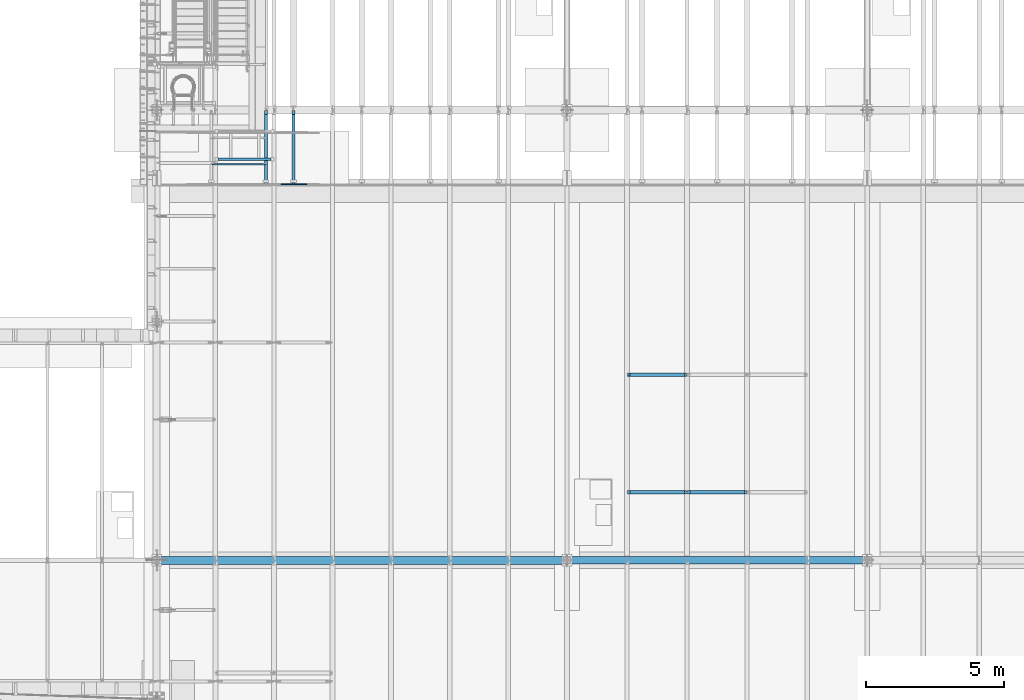
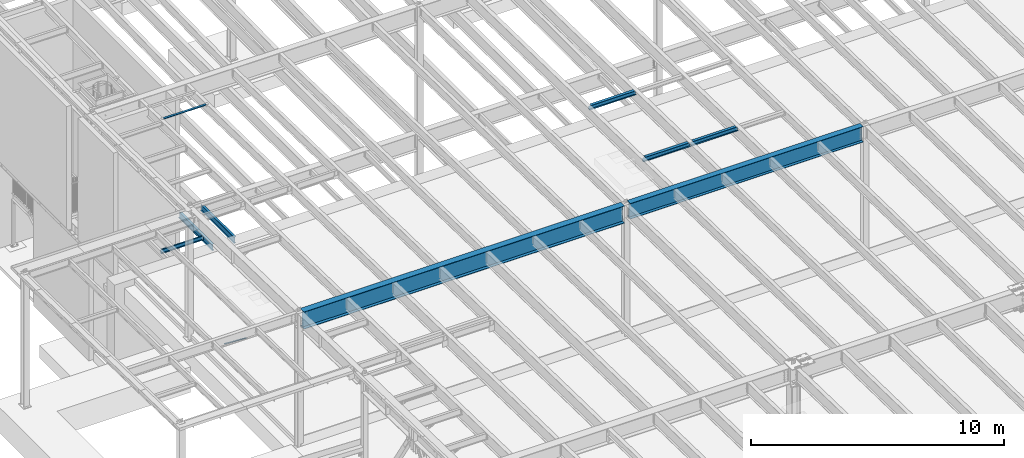
# One storey, part 1074 of 1763: 10 beams, 10 elements without a shape of their own.
"""IFC2X3 building model written with IfcOpenShell, lengths in millimetres."""

from ifc_helpers import new_model, si_unit, frame, origin_with_axes, place, context, subcontext, project, spatial, faceted_brep, material, type_object, element, aggregate, save


model = new_model("IFC2X3")

# Units and contexts
model_context = context("Model", 3, precision=1e-05, world=origin_with_axes())
body_context = subcontext(model_context, "Body", "Model", "MODEL_VIEW")
ifc_project = project(units=[si_unit("LENGTHUNIT", "METRE", prefix="MILLI"), si_unit("AREAUNIT", "SQUARE_METRE"), si_unit("VOLUMEUNIT", "CUBIC_METRE"), si_unit("MASSUNIT", "GRAM", prefix="KILO"), si_unit("TIMEUNIT", "SECOND"), si_unit("PLANEANGLEUNIT", "RADIAN"), si_unit("SOLIDANGLEUNIT", "STERADIAN"), si_unit("THERMODYNAMICTEMPERATUREUNIT", "DEGREE_CELSIUS"), si_unit("LUMINOUSINTENSITYUNIT", "LUMEN")], contexts=[model_context])

# Site, building, storey
site_placement = place(None, origin_with_axes())
site = spatial("IfcSite", under=ifc_project, at=site_placement, CompositionType="ELEMENT")
building_placement = place(site_placement, origin_with_axes())
building = spatial("IfcBuilding", under=site, at=building_placement, Name="Undefined", CompositionType="ELEMENT")
storey_placement = place(building_placement, origin_with_axes())
storey = spatial("IfcBuildingStorey", under=building, at=storey_placement, Name="Undefined", CompositionType="ELEMENT", Elevation=0.0)

# Assembly, beam
assembly_1_placement = place(storey_placement, origin_with_axes())
assembly_1 = element("IfcElementAssembly", 1, at=assembly_1_placement, inside=storey, Name="GUARDRAIL", AssemblyPlace="NOTDEFINED", PredefinedType="RIGID_FRAME")
ifc_material_1 = material()
beam_type_1 = type_object("IfcBeamType", PredefinedType="NOTDEFINED")
beam_1_placement = place(assembly_1_placement, frame((-81897.3716560389, 27343.0999999971, 147.984652267508), z_axis=(0.0, -1.0, 0.0), x_axis=(-0.997891522550524, 0.0, 0.0649038459707657)))
beam_1 = element("IfcBeam", 2, at=beam_1_placement, type_object=beam_type_1, material=ifc_material_1, Name="GUARDRAIL", context=body_context, shape_type="Brep", body=[
    faceted_brep([(1.45519152283669e-11, 1.81898940354586e-12, 19.0499999999993), (8.92561031517107, 9.52499999999873, 16.4977839420935), (10.1646410493704, -9.524999999996, 16.4977839420935), (10.1646410493704, -9.52499999999509, -16.4977839420935), (8.92561031517107, 9.52499999999873, -16.4977839420935), (1.45519152283669e-11, 1.81898940354586e-12, -19.0499999999993), (17.6056747381954, -16.4977839420881, -9.52500000000146), (17.2784488961188, -11.4667123799518, -9.52500000000146), (13.2411789904436, -7.68349999999555, -13.3082123799541), (10.6782988949999, 1.81898940354586e-12, -15.3669999999984), (12.2416941982665, 7.68350000000009, -13.3082123799541), (15.7868363965099, 11.4667123799545, -9.52500000000146), (15.4596105544624, 16.4977839420917, -9.52500000000146), (18.0907665723062, 15.3669999999984, 0.0), (17.8512206303712, 19.0499999999975, 0.0), (16.1615344449092, 13.3082123799541, -7.68349999999919), (16.1615344449092, 13.3082123799541, 7.68349999999919), (15.7868363965099, 11.4667123799545, 9.52500000000146), (15.4596105544624, 16.4977839420917, 9.52500000000146), (12.2416941982665, 7.68350000000009, 13.3082123799541), (10.6782988949999, 1.81898940354586e-12, 15.3669999999984), (13.2411789904436, -7.68349999999646, 13.3082123799541), (17.2784488961188, -11.4667123799518, 9.52500000000146), (17.6056747381954, -16.4977839420881, 9.52500000000146), (17.8926928863511, -13.3082123799504, 7.68349999999919), (20.0897361567768, -15.3669999999947, 0.0), (20.3292820987263, -19.0499999999938, 0.0), (17.8926928863511, -13.3082123799504, -7.68349999999919), (1000.15019855546, 2.72848410531878e-11, 19.0499999999993), (989.985557506108, 9.5250000000251, 16.4977839420935), (982.544523817283, 16.4977839421163, 9.52500000000146), (1000.15019855548, 2.81943357549608e-11, -19.0499999999993), (989.985557506108, 9.5250000000251, -16.4977839420935), (991.224588240293, -9.52499999997053, -16.4977839420935), (984.690588001031, -16.4977839420635, -9.52500000000146), (982.544523817283, 16.4977839421163, -9.52500000000146), (979.820916456767, 19.050000000022, 0.0), (982.257505670044, 13.3082123799786, 7.68349999999919), (980.060462398702, 15.3670000000229, 0.0), (982.87174965936, 11.46671237998, 9.52500000000146), (982.87174965936, 11.46671237998, -9.52500000000146), (982.257505670044, 13.3082123799786, -7.68349999999919), (986.909019565966, 7.68350000002556, -13.3082123799541), (989.47189966141, 2.81943357549608e-11, -15.3669999999984), (987.908504358144, -7.68349999997099, -13.3082123799541), (984.363362158969, -11.4667123799254, -9.52500000000146), (983.988664111486, -13.3082123799259, -7.68349999999919), (982.059431983173, -15.3669999999702, 0.0), (982.298977925122, -19.0499999999693, 0.0), (984.690588001031, -16.4977839420635, 9.52500000000146), (991.224588240293, -9.52499999997053, 16.4977839420935), (984.363362158969, -11.4667123799254, 9.52500000000146), (987.908504358144, -7.68349999997099, 13.3082123799541), (989.47189966141, 2.72848410531878e-11, 15.3669999999984), (986.909019565966, 7.68350000002465, 13.3082123799541), (983.988664111486, -13.3082123799259, 7.68349999999919)], [[[0, 1, 2]], [[3, 4, 5]], [[6, 7, 8, 9, 10, 11, 12, 4, 3]], [[13, 14, 12, 11, 15]], [[16, 17, 18, 14, 13]], [[2, 1, 18, 17, 19, 20, 21, 22, 23]], [[23, 22, 24, 25, 26]], [[26, 25, 27, 7, 6]], [[28, 29, 1, 0]], [[29, 30, 18, 1]], [[31, 32, 33]], [[33, 34, 6, 3]], [[31, 33, 3, 5]], [[32, 31, 5, 4]], [[35, 32, 4, 12]], [[36, 35, 12, 14]], [[30, 36, 14, 18]], [[37, 38, 36, 30, 39]], [[40, 35, 36, 38, 41]], [[33, 32, 35, 40, 42, 43, 44, 45, 34]], [[34, 45, 46, 47, 48]], [[34, 48, 26, 6]], [[49, 50, 2, 23]], [[48, 49, 23, 26]], [[50, 28, 0, 2]], [[28, 50, 29]], [[49, 51, 52, 53, 54, 39, 30, 29, 50]], [[48, 47, 55, 51, 49]], [[55, 47, 25, 24]], [[21, 52, 51, 55, 24, 22]], [[53, 52, 21, 20]], [[54, 53, 20, 19]], [[37, 39, 54, 19, 17, 16]], [[38, 37, 16, 13]], [[41, 38, 13, 15]], [[10, 42, 40, 41, 15, 11]], [[43, 42, 10, 9]], [[44, 43, 9, 8]], [[46, 45, 44, 8, 7, 27]], [[47, 46, 27, 25]]]),
])
aggregate(assembly_1, [beam_1])

assembly_2_placement = place(storey_placement, origin_with_axes())
assembly_2 = element("IfcElementAssembly", 3, at=assembly_2_placement, inside=storey, Name="BEAM", AssemblyPlace="NOTDEFINED", PredefinedType="RIGID_FRAME")
ifc_material_2 = material(Name="STEEL/A992")
beam_type_2 = type_object("IfcBeamType", Name="W8X18", PredefinedType="NOTDEFINED")
beam_2_placement = place(assembly_2_placement, frame((-68132.3972736984, 16154.4, 11477.0442138004), z_axis=(0.0, 0.0, 1.0), x_axis=(1.0, 0.0, 0.0)))
beam_2 = element("IfcBeam", 4, at=beam_2_placement, type_object=beam_type_2, material=ifc_material_2, Name="BEAM", ObjectType="W8X18", context=body_context, shape_type="Brep", body=[
    faceted_brep([(87.3125001907247, -3.17500000000018, 64.8275016680727), (87.3125001907247, 3.17500000000018, 64.8275016680727), (17.4624999999905, 3.17500000000018, 64.8275016680727), (17.4624999999905, -3.17500000000018, 64.8275016680727), (92.1725797087711, -3.17500000000018, 65.7942315906603), (92.1725797087711, 3.17500000000018, 65.7942315906603), (96.2927561769247, -3.17500000000018, 68.5472454911378), (96.2927561769247, 3.17500000000018, 68.5472454911378), (97.1527139098253, -3.17500000000018, 69.8342631898486), (97.1527139098253, 3.17500000000018, 69.8342631898486), (17.4624999999905, -3.17500000000018, -95.25), (17.4624999999905, -66.6750000000002, -95.25), (2161.85750000001, -66.6749999999993, -95.25), (2161.85750000001, -3.17499999999927, -95.25), (17.4624999999905, -66.6750000000002, -103.1875), (2161.85750000001, -66.6749999999993, -103.1875), (17.4624999999905, 66.6750000000002, -103.1875), (2161.85750000001, 66.6749999999993, -103.1875), (17.4624999999905, 66.6750000000002, -95.25), (2161.85750000001, 66.6749999999993, -95.25), (17.4624999999905, 3.17500000000018, -95.25), (2161.85750000001, 3.17499999999927, -95.25), (2161.85750000001, 3.17499999999927, 64.8275016806765), (2161.85750000001, -3.17499999999927, 64.8275016806765), (2092.00749980928, 3.17499999999927, 64.8275016806765), (2092.00749980928, -3.17499999999927, 64.8275016806765), (2087.14742029124, 3.17499999999927, 65.7942316032641), (2087.14742029124, -3.17499999999927, 65.7942316032641), (2083.02724382307, 3.17499999999927, 68.5472455037416), (2083.02724382307, -3.17499999999927, 68.5472455037416), (2082.16728610454, 3.17499999999927, 69.8342631809664), (2082.16728610454, -3.17499999999927, 69.8342631809664), (2081.43974687484, 3.17499999999927, 70.3203893524951), (2081.43974687484, -3.17499999999927, 70.3203893524951), (2078.68673297435, 3.17499999999927, 74.4405658206488), (2078.68673297435, -3.17499999999927, 74.4405658206488), (2077.72000305177, 3.17499999999927, 79.3006453386952), (2077.72000305177, -3.17499999999927, 79.3006453386952), (2077.72000305177, -66.6749999999993, 103.1875), (2077.72000305177, -66.6749999999993, 95.25), (2077.72000305177, -3.17499999999927, 95.25), (2077.72000305177, 3.17499999999927, 95.25), (2077.72000305177, 66.6749999999993, 95.25), (2077.72000305177, 66.6749999999993, 103.1875), (101.599996948244, 3.17500000000018, 95.25), (101.599996948244, 66.6750000000002, 95.25), (101.599996948244, 66.6750000000002, 103.1875), (101.599996948244, -66.6750000000002, 103.1875), (101.599996948244, -66.6750000000002, 95.25), (101.599996948244, -3.17500000000018, 95.25), (101.599996948244, 3.17500000000018, 79.3006453379949), (101.599996948244, -3.17500000000018, 79.3006453379949), (100.633267025656, 3.17500000000018, 74.4405658199485), (100.633267025656, -3.17500000000018, 74.4405658199485), (97.8802531251786, 3.17500000000018, 70.3203893517948), (97.8802531251786, -3.17500000000018, 70.3203893517948)], [[[0, 1, 2, 3]], [[4, 5, 1, 0]], [[6, 7, 5, 4]], [[8, 9, 7, 6]], [[10, 11, 12, 13]], [[11, 14, 15, 12]], [[14, 16, 17, 15]], [[16, 18, 19, 17]], [[18, 20, 21, 19]], [[13, 12, 15, 17, 19, 21, 22, 23]], [[23, 22, 24, 25]], [[25, 24, 26, 27]], [[27, 26, 28, 29]], [[29, 28, 30, 31]], [[32, 33, 31, 30]], [[33, 32, 34, 35]], [[35, 34, 36, 37]], [[38, 39, 40, 37, 36, 41, 42, 43]], [[44, 45, 42, 41]], [[45, 46, 43, 42]], [[46, 47, 38, 43]], [[47, 48, 39, 38]], [[48, 49, 40, 39]], [[47, 46, 45, 44, 50, 51, 49, 48]], [[51, 50, 52, 53]], [[53, 52, 54, 55]], [[4, 0, 3, 10, 13, 23, 25, 27, 29, 31, 33, 35, 37, 40, 49, 51, 53, 55, 8, 6]], [[20, 18, 16, 14, 11, 10, 3, 2]], [[54, 52, 50, 44, 41, 36, 34, 32, 30, 28, 26, 24, 22, 21, 20, 2, 1, 5, 7, 9]], [[55, 54, 9, 8]]]),
])
aggregate(assembly_2, [beam_2])

assembly_3_placement = place(storey_placement, origin_with_axes())
assembly_3 = element("IfcElementAssembly", 5, at=assembly_3_placement, inside=storey, Name="BEAM", AssemblyPlace="NOTDEFINED", PredefinedType="RIGID_FRAME")
beam_3_placement = place(assembly_3_placement, frame((-70311.7172736983, 20421.6, 11387.8344547136), z_axis=(0.0, 0.0, 1.0), x_axis=(1.0, 0.0, 0.0)))
beam_3 = element("IfcBeam", 6, at=beam_3_placement, type_object=beam_type_2, material=ifc_material_2, Name="BEAM", ObjectType="W8X18", context=body_context, shape_type="Brep", body=[
    faceted_brep([(2083.02724382307, -3.17499999999927, 68.5472455037416), (2083.02724382307, 3.17499999999927, 68.5472455037416), (2082.16625903222, 3.17499999999927, 69.8358003002977), (2082.16625903222, -3.17499999999927, 69.8358003002977), (2087.14742029124, -3.17499999999927, 65.7942316032641), (2087.14742029124, 3.17499999999927, 65.7942316032641), (2092.00749980928, -3.17499999999927, 64.8275016806765), (2092.00749980928, 3.17499999999927, 64.8275016806765), (2161.85750000001, -3.17499999999927, 64.8275016806765), (2161.85750000001, 3.17499999999927, 64.8275016806765), (2081.43974687482, -3.17499999999927, 70.3212402040699), (2081.43974687482, 3.17499999999927, 70.3212402040699), (2078.68673297434, 3.17499999999927, 74.4414166722236), (2078.68673297434, -3.17499999999927, 74.4414166722236), (2077.72000305176, 3.17499999999927, 79.30149619027), (2077.72000305176, -3.17499999999927, 79.30149619027), (101.599996948244, 3.17500000000018, 95.25), (101.599996948244, 66.6750000000002, 95.25), (2077.72000305177, 66.6749999999993, 95.25), (2077.72000305177, 3.17499999999927, 95.25), (101.599996948244, -66.6750000000002, 103.1875), (101.599996948244, -66.6750000000002, 95.25), (2077.72000305177, -66.6749999999993, 95.25), (2077.72000305177, -66.6749999999993, 103.1875), (101.599996948244, 66.6750000000002, 103.1875), (2077.72000305177, 66.6749999999993, 103.1875), (2077.72000305177, -3.17499999999927, 95.25), (101.599996948244, -3.17500000000018, 95.25), (101.599996948236, 3.17499999999927, 79.301496189446), (101.599996948236, -3.17499999999927, 79.301496189446), (100.633267025652, 3.17499999999927, 74.4414166713996), (100.633267025652, -3.17499999999927, 74.4414166713996), (97.8802531251713, 3.17499999999927, 70.3212402032459), (97.8802531251713, -3.17499999999927, 70.3212402032459), (97.153740969894, 3.17499999999927, 69.8358003008998), (97.153740969894, -3.17499999999927, 69.8358003008998), (96.2927561769247, 3.17500000000018, 68.5472454911378), (96.2927561769247, -3.17500000000018, 68.5472454911378), (92.1725797087711, 3.17500000000018, 65.7942315906603), (92.1725797087711, -3.17500000000018, 65.7942315906603), (87.3125001907247, 3.17500000000018, 64.8275016680727), (87.3125001907247, -3.17500000000018, 64.8275016680727), (17.4624999999905, 3.17500000000018, 64.8275016680727), (17.4624999999905, -3.17500000000018, 64.8275016680727), (17.4624999999905, 3.17500000000018, -95.25), (17.4624999999905, 66.6750000000002, -95.25), (17.4624999999905, 66.6750000000002, -103.1875), (17.4624999999905, -66.6750000000002, -103.1875), (17.4624999999905, -66.6750000000002, -95.25), (17.4624999999905, -3.17500000000018, -95.25), (2161.85750000001, 3.17499999999927, -95.25), (2161.85750000001, 66.6749999999993, -95.25), (2161.85750000001, 66.6749999999993, -103.1875), (2161.85750000001, -66.6749999999993, -103.1875), (2161.85750000001, -66.6749999999993, -95.25), (2161.85750000001, -3.17499999999927, -95.25)], [[[0, 1, 2, 3]], [[4, 5, 1, 0]], [[6, 7, 5, 4]], [[8, 9, 7, 6]], [[10, 11, 12, 13]], [[13, 12, 14, 15]], [[16, 17, 18, 19]], [[20, 21, 22, 23]], [[24, 20, 23, 25]], [[17, 24, 25, 18]], [[23, 22, 26, 15, 14, 19, 18, 25]], [[21, 27, 26, 22]], [[20, 24, 17, 16, 28, 29, 27, 21]], [[29, 28, 30, 31]], [[31, 30, 32, 33]], [[33, 32, 34, 35]], [[35, 34, 36, 37]], [[37, 36, 38, 39]], [[39, 38, 40, 41]], [[41, 40, 42, 43]], [[44, 45, 46, 47, 48, 49, 43, 42]], [[45, 44, 50, 51]], [[46, 45, 51, 52]], [[47, 46, 52, 53]], [[48, 47, 53, 54]], [[49, 48, 54, 55]], [[4, 0, 3, 10, 13, 15, 26, 27, 29, 31, 33, 35, 37, 39, 41, 43, 49, 55, 8, 6]], [[11, 10, 3, 2]], [[50, 44, 42, 40, 38, 36, 34, 32, 30, 28, 16, 19, 14, 12, 11, 2, 1, 5, 7, 9]], [[55, 54, 53, 52, 51, 50, 9, 8]]]),
])
aggregate(assembly_3, [beam_3])

assembly_4_placement = place(storey_placement, origin_with_axes())
assembly_4 = element("IfcElementAssembly", 7, at=assembly_4_placement, inside=storey, Name="BEAM", AssemblyPlace="NOTDEFINED", PredefinedType="RIGID_FRAME")
beam_4_placement = place(assembly_4_placement, frame((-70311.7172736983, 16154.4, 11477.0442138004), z_axis=(0.0, 0.0, 1.0), x_axis=(1.0, 0.0, 0.0)))
beam_4 = element("IfcBeam", 8, at=beam_4_placement, type_object=beam_type_2, material=ifc_material_2, Name="BEAM", ObjectType="W8X18", context=body_context, shape_type="Brep", body=[
    faceted_brep([(87.3125001907247, -3.17500000000018, 64.8275016680727), (87.3125001907247, 3.17500000000018, 64.8275016680727), (17.4624999999905, 3.17500000000018, 64.8275016680727), (17.4624999999905, -3.17500000000018, 64.8275016680727), (92.1725797087711, -3.17500000000018, 65.7942315906603), (92.1725797087711, 3.17500000000018, 65.7942315906603), (96.2927561769247, -3.17500000000018, 68.5472454911378), (96.2927561769247, 3.17500000000018, 68.5472454911378), (97.1527139098253, -3.17500000000018, 69.8342631898486), (97.1527139098253, 3.17500000000018, 69.8342631898486), (17.4624999999905, -3.17500000000018, -95.25), (17.4624999999905, -66.6750000000002, -95.25), (2161.85750000001, -66.6749999999993, -95.25), (2161.85750000001, -3.17499999999927, -95.25), (17.4624999999905, -66.6750000000002, -103.1875), (2161.85750000001, -66.6749999999993, -103.1875), (17.4624999999905, 66.6750000000002, -103.1875), (2161.85750000001, 66.6749999999993, -103.1875), (17.4624999999905, 66.6750000000002, -95.25), (2161.85750000001, 66.6749999999993, -95.25), (17.4624999999905, 3.17500000000018, -95.25), (2161.85750000001, 3.17499999999927, -95.25), (2161.85750000001, 3.17499999999927, 64.8275016806765), (2161.85750000001, -3.17499999999927, 64.8275016806765), (2092.00749980928, 3.17499999999927, 64.8275016806765), (2092.00749980928, -3.17499999999927, 64.8275016806765), (2087.14742029124, 3.17499999999927, 65.7942316032641), (2087.14742029124, -3.17499999999927, 65.7942316032641), (2083.02724382307, 3.17499999999927, 68.5472455037416), (2083.02724382307, -3.17499999999927, 68.5472455037416), (2082.16728610454, 3.17499999999927, 69.8342631809664), (2082.16728610454, -3.17499999999927, 69.8342631809664), (2081.43974687484, 3.17499999999927, 70.3203893524951), (2081.43974687484, -3.17499999999927, 70.3203893524951), (2078.68673297435, 3.17499999999927, 74.4405658206488), (2078.68673297435, -3.17499999999927, 74.4405658206488), (2077.72000305177, 3.17499999999927, 79.3006453386952), (2077.72000305177, -3.17499999999927, 79.3006453386952), (2077.72000305177, -66.6749999999993, 103.1875), (2077.72000305177, -66.6749999999993, 95.25), (2077.72000305177, -3.17499999999927, 95.25), (2077.72000305177, 3.17499999999927, 95.25), (2077.72000305177, 66.6749999999993, 95.25), (2077.72000305177, 66.6749999999993, 103.1875), (101.599996948244, 3.17500000000018, 95.25), (101.599996948244, 66.6750000000002, 95.25), (101.599996948244, 66.6750000000002, 103.1875), (101.599996948244, -66.6750000000002, 103.1875), (101.599996948244, -66.6750000000002, 95.25), (101.599996948244, -3.17500000000018, 95.25), (101.599996948244, 3.17500000000018, 79.3006453379949), (101.599996948244, -3.17500000000018, 79.3006453379949), (100.633267025656, 3.17500000000018, 74.4405658199485), (100.633267025656, -3.17500000000018, 74.4405658199485), (97.8802531251786, 3.17500000000018, 70.3203893517948), (97.8802531251786, -3.17500000000018, 70.3203893517948)], [[[0, 1, 2, 3]], [[4, 5, 1, 0]], [[6, 7, 5, 4]], [[8, 9, 7, 6]], [[10, 11, 12, 13]], [[11, 14, 15, 12]], [[14, 16, 17, 15]], [[16, 18, 19, 17]], [[18, 20, 21, 19]], [[13, 12, 15, 17, 19, 21, 22, 23]], [[23, 22, 24, 25]], [[25, 24, 26, 27]], [[27, 26, 28, 29]], [[29, 28, 30, 31]], [[32, 33, 31, 30]], [[33, 32, 34, 35]], [[35, 34, 36, 37]], [[38, 39, 40, 37, 36, 41, 42, 43]], [[44, 45, 42, 41]], [[45, 46, 43, 42]], [[46, 47, 38, 43]], [[47, 48, 39, 38]], [[48, 49, 40, 39]], [[47, 46, 45, 44, 50, 51, 49, 48]], [[51, 50, 52, 53]], [[53, 52, 54, 55]], [[4, 0, 3, 10, 13, 23, 25, 27, 29, 31, 33, 35, 37, 40, 49, 51, 53, 55, 8, 6]], [[20, 18, 16, 14, 11, 10, 3, 2]], [[54, 52, 50, 44, 41, 36, 34, 32, 30, 28, 26, 24, 22, 21, 20, 2, 1, 5, 7, 9]], [[55, 54, 9, 8]]]),
])
aggregate(assembly_4, [beam_4])

assembly_5_placement = place(storey_placement, origin_with_axes())
assembly_5 = element("IfcElementAssembly", 9, at=assembly_5_placement, inside=storey, Name="ANGLE", AssemblyPlace="NOTDEFINED", PredefinedType="RIGID_FRAME")
ifc_material_3 = material(Name="STEEL/A36")
beam_type_3 = type_object("IfcBeamType", Name="L4X4X3/8", PredefinedType="NOTDEFINED")
beam_5_placement = place(assembly_5_placement, frame((-85249.0944165555, 28243.7452529459, 11276.6858246509), z_axis=(0.0, -0.999779834654609, 0.0209829029927566), x_axis=(1.0, 0.0, 0.0)))
beam_5 = element("IfcBeam", 10, at=beam_5_placement, type_object=beam_type_3, material=ifc_material_3, Name="ANGLE", ObjectType="L4X4X3/8", context=body_context, shape_type="Brep", body=[
    faceted_brep([(98.4250000000029, 50.7999999999229, -50.8000000000175), (98.4250000000029, 50.8000000000102, 50.8000000001048), (2027.926333111, 50.8000000000102, 50.8000000001048), (2027.926333111, 50.7999999999229, -50.8000000000175), (98.4250000000029, 41.275000000016, 50.8000000000975), (2027.926333111, 41.275000000016, 50.8000000000975), (98.4250000000029, 41.2749999999378, -41.275000000016), (2027.926333111, 41.2749999999378, -41.275000000016), (98.4250000000029, -50.7999999999993, -41.2750000000997), (2027.926333111, -50.7999999999993, -41.2750000000997), (98.4250000000029, -50.800000000012, -50.8000000001084), (2027.926333111, -50.800000000012, -50.8000000001084)], [[[0, 1, 2, 3]], [[1, 4, 5, 2]], [[4, 6, 7, 5]], [[6, 8, 9, 7]], [[8, 10, 11, 9]], [[10, 0, 3, 11]], [[5, 7, 9, 11, 3, 2]], [[10, 8, 6, 4, 1, 0]]]),
])
aggregate(assembly_5, [beam_5])

assembly_6_placement = place(storey_placement, origin_with_axes())
assembly_6 = element("IfcElementAssembly", 11, at=assembly_6_placement, inside=storey, Name="BEAM", AssemblyPlace="NOTDEFINED", PredefinedType="RIGID_FRAME")
beam_type_4 = type_object("IfcBeamType", Name="C8X11.5", PredefinedType="NOTDEFINED")
beam_6_placement = place(assembly_6_placement, frame((-85394.1576116291, 28054.3, 5092.7), z_axis=(0.0, 0.0, 1.0), x_axis=(1.0, 0.0, 0.0)))
beam_6 = element("IfcBeam", 12, at=beam_6_placement, type_object=beam_type_4, material=ifc_material_3, Name="BEAM", ObjectType="C8X11.5", context=body_context, shape_type="Brep", body=[
    faceted_brep([(1914.44533793071, -28.5750000000007, 101.6), (1914.44533793071, -28.5750000000007, 96.8355949999996), (1914.44533793071, 22.2249999999985, 88.3723149999996), (1914.44533793071, 22.2249999999985, 82.5499998092646), (1914.44533793071, 28.5750000000007, 82.5499998092646), (1914.44533793071, 28.5750000000007, 101.6), (1915.41206785329, 22.2249999999985, 77.6899202912191), (1915.41206785329, 28.5750000000007, 77.6899202912191), (1918.16508175377, 22.2249999999985, 73.5697438230654), (1918.16508175377, 28.5750000000007, 73.5697438230654), (1922.28525822193, 22.2249999999985, 70.816729922587), (1922.28525822193, 28.5750000000007, 70.816729922587), (1927.14533773997, 22.2249999999985, 69.8499999999995), (1927.14533773997, 28.5750000000007, 69.8499999999995), (1965.24533793071, 22.2249999999985, 69.8499999999995), (1965.24533793071, 28.5750000000007, 69.8499999999995), (66.6749999999884, -28.5750000000007, 101.6), (66.6749999999884, 28.5750000000007, 101.6), (66.6749999999884, 28.5750000000007, 82.5499998092646), (66.6749999999884, 22.2249999999985, 82.5499998092646), (66.6749999999884, 22.2249999999985, 88.3723149999996), (66.6749999999884, -28.5750000000007, 96.8355949999996), (65.7082700774044, 28.5750000000007, 77.6899202912191), (65.7082700774044, 22.2249999999985, 77.6899202912191), (62.9552561769233, 28.5750000000007, 73.5697438230654), (62.9552561769233, 22.2249999999985, 73.5697438230654), (58.8350797087624, 28.5750000000007, 70.816729922587), (58.8350797087624, 22.2249999999985, 70.816729922587), (53.9750001907232, 28.5750000000007, 69.8499999999995), (53.9750001907232, 22.2249999999985, 69.8499999999995), (15.8749999999854, 28.5750000000007, 69.8499999999995), (15.8749999999854, 22.2249999999985, 69.8499999999995), (15.8749999999854, 28.5750000000007, -101.6), (15.8749999999854, -28.5750000000007, -101.6), (15.8749999999854, -28.5750000000007, -96.8355949999996), (15.8749999999854, 22.2249999999985, -88.3723149999996), (1965.24533793071, 28.5750000000007, -101.6), (1965.24533793071, -28.5750000000007, -101.6), (1965.24533793071, -28.5750000000007, -96.8355949999996), (1965.24533793071, 22.2249999999985, -88.3723149999996)], [[[0, 1, 2, 3, 4, 5]], [[6, 7, 4, 3]], [[8, 9, 7, 6]], [[10, 11, 9, 8]], [[12, 13, 11, 10]], [[14, 15, 13, 12]], [[16, 17, 18, 19, 20, 21]], [[19, 18, 22, 23]], [[23, 22, 24, 25]], [[25, 24, 26, 27]], [[27, 26, 28, 29]], [[29, 28, 30, 31]], [[32, 33, 34, 35, 31, 30]], [[33, 32, 36, 37]], [[34, 33, 37, 38]], [[35, 34, 38, 39]], [[23, 25, 27, 29, 31, 35, 39, 14, 12, 10, 8, 6, 3, 2, 20, 19]], [[2, 1, 21, 20]], [[1, 0, 16, 21]], [[0, 5, 17, 16]], [[5, 4, 7, 9, 11, 13, 15, 36, 32, 30, 28, 26, 24, 22, 18, 17]], [[39, 38, 37, 36, 15, 14]]]),
])
aggregate(assembly_6, [beam_6])

assembly_7_placement = place(storey_placement, origin_with_axes())
assembly_7 = element("IfcElementAssembly", 13, at=assembly_7_placement, inside=storey, Name="BEAM", AssemblyPlace="NOTDEFINED", PredefinedType="RIGID_FRAME")
beam_type_5 = type_object("IfcBeamType", Name="W12X16", PredefinedType="NOTDEFINED")
beam_7_placement = place(assembly_7_placement, frame((-82413.9706070317, 27279.6, 5041.9), z_axis=(0.0, 0.0, 1.0), x_axis=(0.0, 1.0, 0.0)))
beam_7 = element("IfcBeam", 14, at=beam_7_placement, type_object=beam_type_5, material=ifc_material_2, Name="BEAM", ObjectType="W12X16", context=body_context, shape_type="Brep", body=[
    faceted_brep([(63.5000000000036, -3.17499999999927, -146.05), (63.5000000000036, -50.7999999999993, -146.05), (2723.35625, -50.8000000000029, -146.05), (2723.35625, -3.17500000000291, -146.05), (63.5000000000036, -50.7999999999993, -152.4), (2723.35625, -50.8000000000029, -152.4), (63.5000000000036, 50.7999999999993, -152.4), (2723.35625, 50.8000000000029, -152.4), (63.5000000000036, 50.7999999999993, -146.05), (63.5000000000036, 3.17499999999927, -146.05), (2723.35625, 3.17500000000291, -146.05), (2723.35625, 50.8000000000029, -146.05), (2723.35625, 3.17500000000291, 120.390001678466), (2723.35625, -3.17500000000291, 120.390001678466), (63.5000000000036, -3.17499999999927, 146.05), (63.5000000000036, -50.7999999999993, 146.05), (63.5000000000036, -50.7999999999993, 152.4), (63.5000000000036, 50.7999999999993, 152.4), (63.5000000000036, 50.7999999999993, 146.05), (63.5000000000036, 3.17499999999927, 146.05), (2583.65625, 50.8000000000029, 146.05), (2583.65625, 3.17500000000291, 146.05), (2583.65625, 3.17500000000291, 133.090001487732), (2584.62297992259, 3.17500000000291, 128.229921969686), (2587.37599382307, 3.17500000000291, 124.109745501532), (2591.49617029122, 3.17500000000291, 121.356731601054), (2596.35624980927, 3.17500000000291, 120.390001678466), (2584.62297992259, -3.17500000000291, 128.229921969686), (2583.65625, -3.17500000000291, 133.090001487732), (2587.37599382307, -3.17500000000291, 124.109745501532), (2591.49617029122, -3.17500000000291, 121.356731601054), (2596.35624980927, -3.17500000000291, 120.390001678466), (2583.65625, -3.17500000000291, 146.05), (2583.65625, -50.8000000000029, 146.05), (2583.65625, -50.8000000000029, 152.4), (2583.65625, 50.8000000000029, 152.4)], [[[0, 1, 2, 3]], [[1, 4, 5, 2]], [[4, 6, 7, 5]], [[8, 9, 10, 11]], [[3, 2, 5, 7, 11, 10, 12, 13]], [[6, 8, 11, 7]], [[4, 1, 0, 14, 15, 16, 17, 18, 19, 9, 8, 6]], [[19, 18, 20, 21]], [[10, 9, 19, 21, 22, 23, 24, 25, 26, 12]], [[27, 23, 22, 28]], [[29, 24, 23, 27]], [[30, 25, 24, 29]], [[31, 26, 25, 30]], [[13, 12, 26, 31]], [[30, 29, 27, 28, 32, 14, 0, 3, 13, 31]], [[15, 14, 32, 33]], [[16, 15, 33, 34]], [[17, 16, 34, 35]], [[18, 17, 35, 20]], [[34, 33, 32, 28, 22, 21, 20, 35]]]),
])
aggregate(assembly_7, [beam_7])

assembly_8_placement = place(storey_placement, origin_with_axes())
assembly_8 = element("IfcElementAssembly", 15, at=assembly_8_placement, inside=storey, Name="BEAM", AssemblyPlace="NOTDEFINED", PredefinedType="RIGID_FRAME")
beam_8_placement = place(assembly_8_placement, frame((-83413.0372736983, 27279.6, 5041.9), z_axis=(0.0, 0.0, 1.0), x_axis=(0.0, 1.0, 0.0)))
beam_8 = element("IfcBeam", 16, at=beam_8_placement, type_object=beam_type_5, material=ifc_material_2, Name="BEAM", ObjectType="W12X16", context=body_context, shape_type="Brep", body=[
    faceted_brep([(63.5000000000036, -3.17499999999927, -146.05), (63.5000000000036, -50.7999999999993, -146.05), (2723.35625, -50.8000000000029, -146.05), (2723.35625, -3.17500000000291, -146.05), (63.5000000000036, -50.7999999999993, -152.4), (2723.35625, -50.8000000000029, -152.4), (63.5000000000036, 50.7999999999993, -152.4), (2723.35625, 50.8000000000029, -152.4), (63.5000000000036, 50.7999999999993, -146.05), (63.5000000000036, 3.17499999999927, -146.05), (2723.35625, 3.17500000000291, -146.05), (2723.35625, 50.8000000000029, -146.05), (2723.35625, 3.17500000000291, 120.390001678466), (2723.35625, -3.17500000000291, 120.390001678466), (63.5000000000036, -3.17499999999927, 146.05), (63.5000000000036, -50.7999999999993, 146.05), (63.5000000000036, -50.7999999999993, 152.4), (63.5000000000036, 50.7999999999993, 152.4), (63.5000000000036, 50.7999999999993, 146.05), (63.5000000000036, 3.17499999999927, 146.05), (2583.65625, 50.8000000000029, 146.05), (2583.65625, 3.17500000000291, 146.05), (2583.65625, 3.17500000000291, 133.090001487732), (2584.62297992259, 3.17500000000291, 128.229921969686), (2587.37599382307, 3.17500000000291, 124.109745501532), (2591.49617029122, 3.17500000000291, 121.356731601054), (2596.35624980927, 3.17500000000291, 120.390001678466), (2584.62297992259, -3.17500000000291, 128.229921969686), (2583.65625, -3.17500000000291, 133.090001487732), (2587.37599382307, -3.17500000000291, 124.109745501532), (2591.49617029122, -3.17500000000291, 121.356731601054), (2596.35624980927, -3.17500000000291, 120.390001678466), (2583.65625, -3.17500000000291, 146.05), (2583.65625, -50.8000000000029, 146.05), (2583.65625, -50.8000000000029, 152.4), (2583.65625, 50.8000000000029, 152.4)], [[[0, 1, 2, 3]], [[1, 4, 5, 2]], [[4, 6, 7, 5]], [[8, 9, 10, 11]], [[3, 2, 5, 7, 11, 10, 12, 13]], [[6, 8, 11, 7]], [[4, 1, 0, 14, 15, 16, 17, 18, 19, 9, 8, 6]], [[19, 18, 20, 21]], [[10, 9, 19, 21, 22, 23, 24, 25, 26, 12]], [[27, 23, 22, 28]], [[29, 24, 23, 27]], [[30, 25, 24, 29]], [[31, 26, 25, 30]], [[13, 12, 26, 31]], [[30, 29, 27, 28, 32, 14, 0, 3, 13, 31]], [[15, 14, 32, 33]], [[16, 15, 33, 34]], [[17, 16, 34, 35]], [[18, 17, 35, 20]], [[34, 33, 32, 28, 22, 21, 20, 35]]]),
])
aggregate(assembly_8, [beam_8])

assembly_9_placement = place(storey_placement, origin_with_axes())
assembly_9 = element("IfcElementAssembly", 17, at=assembly_9_placement, inside=storey, Name="BEAM", AssemblyPlace="NOTDEFINED", PredefinedType="RIGID_FRAME")
beam_type_6 = type_object("IfcBeamType", Name="W30X90", PredefinedType="NOTDEFINED")
beam_9_placement = place(assembly_9_placement, frame((-72491.0372736984, 13690.599999996, 11257.0897294638), z_axis=(0.0, 0.0, 1.0), x_axis=(1.0, 0.0, 0.0)))
beam_9 = element("IfcBeam", 18, at=beam_9_placement, type_object=beam_type_6, material=ifc_material_2, Name="BEAM", ObjectType="W30X90", context=body_context, shape_type="Brep", body=[
    faceted_brep([(139.699999999997, 131.762500000001, -374.65), (139.699999999997, 131.762500000001, -358.775), (10756.9, 131.762500000001, -358.775), (10756.9, 131.762500000001, -374.65), (139.699999999997, 6.35000000000036, -358.775), (10756.9, 6.35000000000036, -358.775), (139.699999999997, 6.35000000000036, 358.775), (10756.9, 6.35000000000036, 358.775), (139.699999999997, 131.762500000001, 358.775), (10756.9, 131.762500000001, 358.775), (139.699999999997, 131.762500000001, 374.65), (10756.9, 131.762500000001, 374.65), (139.699999999997, -131.762500000001, 374.65), (10756.9, -131.762500000001, 374.65), (139.699999999997, -131.762500000001, 358.775), (10756.9, -131.762500000001, 358.775), (139.699999999997, -6.35000000000036, 358.775), (10756.9, -6.35000000000036, 358.775), (139.699999999997, -6.35000000000036, -358.775), (10756.9, -6.35000000000036, -358.775), (139.699999999997, -131.762500000001, -358.775), (10756.9, -131.762500000001, -358.775), (139.699999999997, -131.762500000001, -374.65), (10756.9, -131.762500000001, -374.65)], [[[0, 1, 2, 3]], [[1, 4, 5, 2]], [[4, 6, 7, 5]], [[6, 8, 9, 7]], [[8, 10, 11, 9]], [[10, 12, 13, 11]], [[12, 14, 15, 13]], [[14, 16, 17, 15]], [[16, 18, 19, 17]], [[18, 20, 21, 19]], [[20, 22, 23, 21]], [[22, 0, 3, 23]], [[5, 7, 9, 11, 13, 15, 17, 19, 21, 23, 3, 2]], [[22, 20, 18, 16, 14, 12, 10, 8, 6, 4, 1, 0]]]),
])
aggregate(assembly_9, [beam_9])

assembly_10_placement = place(storey_placement, origin_with_axes())
assembly_10 = element("IfcElementAssembly", 19, at=assembly_10_placement, inside=storey, Name="BEAM", AssemblyPlace="NOTDEFINED", PredefinedType="RIGID_FRAME")
beam_type_7 = type_object("IfcBeamType", Name="W33X118", PredefinedType="NOTDEFINED")
beam_10_placement = place(assembly_10_placement, frame((-87375.4372736983, 13690.599999996, 11214.2272294638), z_axis=(0.0, 0.0, 1.0), x_axis=(1.0, 0.0, 0.0)))
beam_10 = element("IfcBeam", 20, at=beam_10_placement, type_object=beam_type_7, material=ifc_material_2, Name="BEAM", ObjectType="W33X118", context=body_context, shape_type="Brep", body=[
    faceted_brep([(139.699999999997, 146.049999999999, -417.512500000001), (139.699999999997, 146.049999999999, -398.4625), (14744.7, 146.049999999999, -398.4625), (14744.7, 146.049999999999, -417.512500000001), (139.699999999997, 7.14374999999927, -398.4625), (14744.7, 7.14374999999927, -398.4625), (139.699999999997, 7.14374999999927, 398.4625), (14744.7, 7.14374999999927, 398.4625), (139.699999999997, 146.049999999999, 398.4625), (14744.7, 146.049999999999, 398.4625), (139.699999999997, 146.049999999999, 417.512500000001), (14744.7, 146.049999999999, 417.512500000001), (139.699999999997, -146.049999999999, 417.512500000001), (14744.7, -146.049999999999, 417.512500000001), (139.699999999997, -146.049999999999, 398.4625), (14744.7, -146.049999999999, 398.4625), (139.699999999997, -7.14374999999927, 398.4625), (14744.7, -7.14374999999927, 398.4625), (139.699999999997, -7.14374999999927, -398.4625), (14744.7, -7.14374999999927, -398.4625), (139.699999999997, -146.049999999999, -398.4625), (14744.7, -146.049999999999, -398.4625), (139.699999999997, -146.049999999999, -417.512500000001), (14744.7, -146.049999999999, -417.512500000001)], [[[0, 1, 2, 3]], [[1, 4, 5, 2]], [[4, 6, 7, 5]], [[6, 8, 9, 7]], [[8, 10, 11, 9]], [[10, 12, 13, 11]], [[12, 14, 15, 13]], [[14, 16, 17, 15]], [[16, 18, 19, 17]], [[18, 20, 21, 19]], [[20, 22, 23, 21]], [[22, 0, 3, 23]], [[5, 7, 9, 11, 13, 15, 17, 19, 21, 23, 3, 2]], [[22, 20, 18, 16, 14, 12, 10, 8, 6, 4, 1, 0]]]),
])
aggregate(assembly_10, [beam_10])

save(model, "model.ifc")
